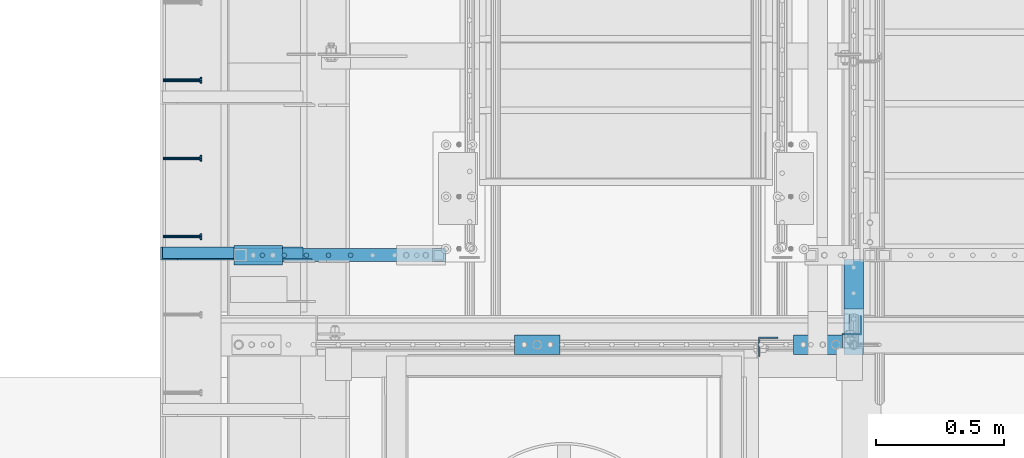
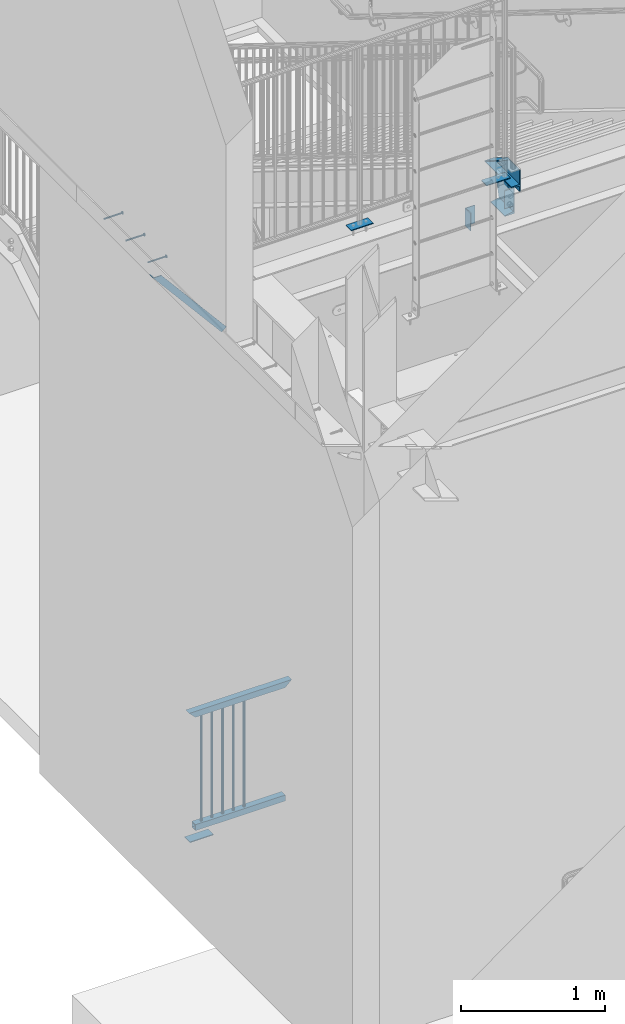
# One storey, part 1257 of 1763: 16 beams, 2 members, 8 elements without a shape of their own.
"""IFC2X3 building model written with IfcOpenShell, lengths in millimetres."""

from ifc_helpers import new_model, si_unit, frame, origin_with_axes, place, context, subcontext, project, spatial, faceted_brep, material, type_object, element, aggregate, save


model = new_model("IFC2X3")

# Units and contexts
model_context = context("Model", 3, precision=1e-05, world=origin_with_axes())
body_context = subcontext(model_context, "Body", "Model", "MODEL_VIEW")
ifc_project = project(units=[si_unit("LENGTHUNIT", "METRE", prefix="MILLI"), si_unit("AREAUNIT", "SQUARE_METRE"), si_unit("VOLUMEUNIT", "CUBIC_METRE"), si_unit("MASSUNIT", "GRAM", prefix="KILO"), si_unit("TIMEUNIT", "SECOND"), si_unit("PLANEANGLEUNIT", "RADIAN"), si_unit("SOLIDANGLEUNIT", "STERADIAN"), si_unit("THERMODYNAMICTEMPERATUREUNIT", "DEGREE_CELSIUS"), si_unit("LUMINOUSINTENSITYUNIT", "LUMEN")], contexts=[model_context])

# Site, building, storey
site_placement = place(None, origin_with_axes())
site = spatial("IfcSite", under=ifc_project, at=site_placement, CompositionType="ELEMENT")
building_placement = place(site_placement, origin_with_axes())
building = spatial("IfcBuilding", under=site, at=building_placement, Name="Undefined", CompositionType="ELEMENT")
storey_placement = place(building_placement, origin_with_axes())
storey = spatial("IfcBuildingStorey", under=building, at=storey_placement, Name="Undefined", CompositionType="ELEMENT", Elevation=0.0)

# Assembly, beam
assembly_1_placement = place(storey_placement, origin_with_axes())
assembly_1 = element("IfcElementAssembly", 1, at=assembly_1_placement, inside=storey, Name="HEADED STUD ANCHOR", AssemblyPlace="NOTDEFINED", PredefinedType="RIGID_FRAME")
ifc_material_1 = material(Name="STEEL/A108")
beam_type_1 = type_object("IfcBeamType", PredefinedType="NOTDEFINED")
beam_1_placement = place(assembly_1_placement, frame((-87975.5122736983, 32096.0750061035, 5268.91250001202), z_axis=(0.0, 0.0, -1.0), x_axis=(1.0, 0.0, 0.0)))
beam_1 = element("IfcBeam", 2, at=beam_1_placement, type_object=beam_type_1, material=ifc_material_1, Name="HEADED STUD ANCHOR", context=body_context, shape_type="Brep", body=[
    faceted_brep([(0.0, -3.1800000667572, 5.5), (0.0, -5.5, 3.1800000667572), (141.732000000002, -5.5, 3.1800000667572), (141.732000000002, -3.1800000667572, 5.5), (0.0, -6.34999999999491, 1.45519152283669e-11), (141.732000000002, -6.34999990463257, 0.0), (0.0, -5.5, -3.1800000667572), (141.732000000002, -5.5, -3.1800000667572), (0.0, -3.1800000667572, -5.5), (141.732000000002, -3.1800000667572, -5.5), (0.0, 0.0, -6.34999990463257), (141.732000000002, 0.0, -6.34999990463257), (0.0, 3.1800000667572, -5.5), (141.732000000002, 3.1800000667572, -5.5), (0.0, 5.5, -3.1800000667572), (141.732000000002, 5.5, -3.1800000667572), (0.0, 6.34999999999491, -2.91038304567337e-11), (141.732000000002, 6.34999990463257, 0.0), (0.0, 5.5, 3.1800000667572), (141.732000000002, 5.5, 3.1800000667572), (0.0, 3.1800000667572, 5.5), (141.732000000002, 3.1800000667572, 5.5), (0.0, 0.0, 6.34999990463257), (141.732000000002, 0.0, 6.34999990463257), (144.780000000001, -10.9899997711182, 6.34999990463257), (144.780000000001, -6.34000015258789, 10.9899997711182), (144.780000000001, -12.6999998092651, 0.0), (144.780000000001, -10.9899997711182, -6.34999990463257), (144.780000000001, -6.34000015258789, -10.9899997711182), (144.780000000001, 0.0, -12.6899995803833), (144.780000000001, 6.34000015258789, -10.9899997711182), (144.780000000001, 10.9899997711182, -6.34999990463257), (144.780000000001, 12.6999998092651, 0.0), (144.780000000001, 10.9899997711182, 6.34999990463257), (144.780000000001, 6.34000015258789, 10.9899997711182), (144.780000000001, 0.0, 12.6899995803833), (152.400000000001, -10.9899997711182, 6.34999990463257), (152.400000000001, -6.34000015258789, 10.9899997711182), (152.400000000001, -12.6999998092651, 0.0), (152.400000000001, -10.9899997711182, -6.34999990463257), (152.400000000001, -6.34000015258789, -10.9899997711182), (152.400000000001, 0.0, -12.6899995803833), (152.400000000001, 6.34000015258789, -10.9899997711182), (152.400000000001, 10.9899997711182, -6.34999990463257), (152.400000000001, 12.6999998092651, 0.0), (152.400000000001, 10.9899997711182, 6.34999990463257), (152.400000000001, 6.34000015258789, 10.9899997711182), (152.400000000001, 0.0, 12.6899995803833)], [[[0, 1, 2, 3]], [[1, 4, 5, 2]], [[4, 6, 7, 5]], [[6, 8, 9, 7]], [[8, 10, 11, 9]], [[10, 12, 13, 11]], [[12, 14, 15, 13]], [[14, 16, 17, 15]], [[16, 18, 19, 17]], [[18, 20, 21, 19]], [[20, 22, 23, 21]], [[22, 0, 3, 23]], [[22, 20, 18, 16, 14, 12, 10, 8, 6, 4, 1, 0]], [[3, 2, 24, 25]], [[2, 5, 26, 24]], [[5, 7, 27, 26]], [[7, 9, 28, 27]], [[9, 11, 29, 28]], [[11, 13, 30, 29]], [[13, 15, 31, 30]], [[15, 17, 32, 31]], [[17, 19, 33, 32]], [[19, 21, 34, 33]], [[21, 23, 35, 34]], [[23, 3, 25, 35]], [[25, 24, 36, 37]], [[24, 26, 38, 36]], [[26, 27, 39, 38]], [[27, 28, 40, 39]], [[28, 29, 41, 40]], [[29, 30, 42, 41]], [[30, 31, 43, 42]], [[31, 32, 44, 43]], [[32, 33, 45, 44]], [[33, 34, 46, 45]], [[34, 35, 47, 46]], [[35, 25, 37, 47]], [[38, 39, 40, 41, 42, 43, 44, 45, 46, 47, 37, 36]]]),
])
aggregate(assembly_1, [beam_1])

assembly_2_placement = place(storey_placement, origin_with_axes())
assembly_2 = element("IfcElementAssembly", 3, at=assembly_2_placement, inside=storey, Name="HEADED STUD ANCHOR", AssemblyPlace="NOTDEFINED", PredefinedType="RIGID_FRAME")
beam_2_placement = place(assembly_2_placement, frame((-87975.5122736983, 32400.8750061035, 5268.91250001202), z_axis=(0.0, 0.0, -1.0), x_axis=(1.0, 0.0, 0.0)))
beam_2 = element("IfcBeam", 4, at=beam_2_placement, type_object=beam_type_1, material=ifc_material_1, Name="HEADED STUD ANCHOR", context=body_context, shape_type="Brep", body=[
    faceted_brep([(0.0, -3.1800000667572, 5.5), (0.0, -5.5, 3.1800000667572), (141.732000000002, -5.5, 3.1800000667572), (141.732000000002, -3.1800000667572, 5.5), (0.0, -6.34999999999491, 1.45519152283669e-11), (141.732000000002, -6.34999990463257, 0.0), (0.0, -5.5, -3.1800000667572), (141.732000000002, -5.5, -3.1800000667572), (0.0, -3.1800000667572, -5.5), (141.732000000002, -3.1800000667572, -5.5), (0.0, 0.0, -6.34999990463257), (141.732000000002, 0.0, -6.34999990463257), (0.0, 3.1800000667572, -5.5), (141.732000000002, 3.1800000667572, -5.5), (0.0, 5.5, -3.1800000667572), (141.732000000002, 5.5, -3.1800000667572), (0.0, 6.34999999999491, -2.91038304567337e-11), (141.732000000002, 6.34999990463257, 0.0), (0.0, 5.5, 3.1800000667572), (141.732000000002, 5.5, 3.1800000667572), (0.0, 3.1800000667572, 5.5), (141.732000000002, 3.1800000667572, 5.5), (0.0, 0.0, 6.34999990463257), (141.732000000002, 0.0, 6.34999990463257), (144.780000000001, -10.9899997711182, 6.34999990463257), (144.780000000001, -6.34000015258789, 10.9899997711182), (144.780000000001, -12.6999998092651, 0.0), (144.780000000001, -10.9899997711182, -6.34999990463257), (144.780000000001, -6.34000015258789, -10.9899997711182), (144.780000000001, 0.0, -12.6899995803833), (144.780000000001, 6.34000015258789, -10.9899997711182), (144.780000000001, 10.9899997711182, -6.34999990463257), (144.780000000001, 12.6999998092651, 0.0), (144.780000000001, 10.9899997711182, 6.34999990463257), (144.780000000001, 6.34000015258789, 10.9899997711182), (144.780000000001, 0.0, 12.6899995803833), (152.400000000001, -10.9899997711182, 6.34999990463257), (152.400000000001, -6.34000015258789, 10.9899997711182), (152.400000000001, -12.6999998092651, 0.0), (152.400000000001, -10.9899997711182, -6.34999990463257), (152.400000000001, -6.34000015258789, -10.9899997711182), (152.400000000001, 0.0, -12.6899995803833), (152.400000000001, 6.34000015258789, -10.9899997711182), (152.400000000001, 10.9899997711182, -6.34999990463257), (152.400000000001, 12.6999998092651, 0.0), (152.400000000001, 10.9899997711182, 6.34999990463257), (152.400000000001, 6.34000015258789, 10.9899997711182), (152.400000000001, 0.0, 12.6899995803833)], [[[0, 1, 2, 3]], [[1, 4, 5, 2]], [[4, 6, 7, 5]], [[6, 8, 9, 7]], [[8, 10, 11, 9]], [[10, 12, 13, 11]], [[12, 14, 15, 13]], [[14, 16, 17, 15]], [[16, 18, 19, 17]], [[18, 20, 21, 19]], [[20, 22, 23, 21]], [[22, 0, 3, 23]], [[22, 20, 18, 16, 14, 12, 10, 8, 6, 4, 1, 0]], [[3, 2, 24, 25]], [[2, 5, 26, 24]], [[5, 7, 27, 26]], [[7, 9, 28, 27]], [[9, 11, 29, 28]], [[11, 13, 30, 29]], [[13, 15, 31, 30]], [[15, 17, 32, 31]], [[17, 19, 33, 32]], [[19, 21, 34, 33]], [[21, 23, 35, 34]], [[23, 3, 25, 35]], [[25, 24, 36, 37]], [[24, 26, 38, 36]], [[26, 27, 39, 38]], [[27, 28, 40, 39]], [[28, 29, 41, 40]], [[29, 30, 42, 41]], [[30, 31, 43, 42]], [[31, 32, 44, 43]], [[32, 33, 45, 44]], [[33, 34, 46, 45]], [[34, 35, 47, 46]], [[35, 25, 37, 47]], [[38, 39, 40, 41, 42, 43, 44, 45, 46, 47, 37, 36]]]),
])
aggregate(assembly_2, [beam_2])

assembly_3_placement = place(storey_placement, origin_with_axes())
assembly_3 = element("IfcElementAssembly", 5, at=assembly_3_placement, inside=storey, Name="HEADED STUD ANCHOR", AssemblyPlace="NOTDEFINED", PredefinedType="RIGID_FRAME")
beam_3_placement = place(assembly_3_placement, frame((-87975.5122736983, 32705.6750061035, 5268.91250001202), z_axis=(0.0, 0.0, -1.0), x_axis=(1.0, 0.0, 0.0)))
beam_3 = element("IfcBeam", 6, at=beam_3_placement, type_object=beam_type_1, material=ifc_material_1, Name="HEADED STUD ANCHOR", context=body_context, shape_type="Brep", body=[
    faceted_brep([(0.0, -3.1800000667572, 5.5), (0.0, -5.5, 3.1800000667572), (141.732000000002, -5.5, 3.1800000667572), (141.732000000002, -3.1800000667572, 5.5), (0.0, -6.34999999999491, 1.45519152283669e-11), (141.732000000002, -6.34999990463257, 0.0), (0.0, -5.5, -3.1800000667572), (141.732000000002, -5.5, -3.1800000667572), (0.0, -3.1800000667572, -5.5), (141.732000000002, -3.1800000667572, -5.5), (0.0, 0.0, -6.34999990463257), (141.732000000002, 0.0, -6.34999990463257), (0.0, 3.1800000667572, -5.5), (141.732000000002, 3.1800000667572, -5.5), (0.0, 5.5, -3.1800000667572), (141.732000000002, 5.5, -3.1800000667572), (0.0, 6.34999999999491, -2.91038304567337e-11), (141.732000000002, 6.34999990463257, 0.0), (0.0, 5.5, 3.1800000667572), (141.732000000002, 5.5, 3.1800000667572), (0.0, 3.1800000667572, 5.5), (141.732000000002, 3.1800000667572, 5.5), (0.0, 0.0, 6.34999990463257), (141.732000000002, 0.0, 6.34999990463257), (144.780000000001, -10.9899997711182, 6.34999990463257), (144.780000000001, -6.34000015258789, 10.9899997711182), (144.780000000001, -12.6999998092651, 0.0), (144.780000000001, -10.9899997711182, -6.34999990463257), (144.780000000001, -6.34000015258789, -10.9899997711182), (144.780000000001, 0.0, -12.6899995803833), (144.780000000001, 6.34000015258789, -10.9899997711182), (144.780000000001, 10.9899997711182, -6.34999990463257), (144.780000000001, 12.6999998092651, 0.0), (144.780000000001, 10.9899997711182, 6.34999990463257), (144.780000000001, 6.34000015258789, 10.9899997711182), (144.780000000001, 0.0, 12.6899995803833), (152.400000000001, -10.9899997711182, 6.34999990463257), (152.400000000001, -6.34000015258789, 10.9899997711182), (152.400000000001, -12.6999998092651, 0.0), (152.400000000001, -10.9899997711182, -6.34999990463257), (152.400000000001, -6.34000015258789, -10.9899997711182), (152.400000000001, 0.0, -12.6899995803833), (152.400000000001, 6.34000015258789, -10.9899997711182), (152.400000000001, 10.9899997711182, -6.34999990463257), (152.400000000001, 12.6999998092651, 0.0), (152.400000000001, 10.9899997711182, 6.34999990463257), (152.400000000001, 6.34000015258789, 10.9899997711182), (152.400000000001, 0.0, 12.6899995803833)], [[[0, 1, 2, 3]], [[1, 4, 5, 2]], [[4, 6, 7, 5]], [[6, 8, 9, 7]], [[8, 10, 11, 9]], [[10, 12, 13, 11]], [[12, 14, 15, 13]], [[14, 16, 17, 15]], [[16, 18, 19, 17]], [[18, 20, 21, 19]], [[20, 22, 23, 21]], [[22, 0, 3, 23]], [[22, 20, 18, 16, 14, 12, 10, 8, 6, 4, 1, 0]], [[3, 2, 24, 25]], [[2, 5, 26, 24]], [[5, 7, 27, 26]], [[7, 9, 28, 27]], [[9, 11, 29, 28]], [[11, 13, 30, 29]], [[13, 15, 31, 30]], [[15, 17, 32, 31]], [[17, 19, 33, 32]], [[19, 21, 34, 33]], [[21, 23, 35, 34]], [[23, 3, 25, 35]], [[25, 24, 36, 37]], [[24, 26, 38, 36]], [[26, 27, 39, 38]], [[27, 28, 40, 39]], [[28, 29, 41, 40]], [[29, 30, 42, 41]], [[30, 31, 43, 42]], [[31, 32, 44, 43]], [[32, 33, 45, 44]], [[33, 34, 46, 45]], [[34, 35, 47, 46]], [[35, 25, 37, 47]], [[38, 39, 40, 41, 42, 43, 44, 45, 46, 47, 37, 36]]]),
])
aggregate(assembly_3, [beam_3])

assembly_4_placement = place(storey_placement, origin_with_axes())
assembly_4 = element("IfcElementAssembly", 7, at=assembly_4_placement, inside=storey, Name="STRINGER", AssemblyPlace="NOTDEFINED", PredefinedType="RIGID_FRAME")
ifc_material_2 = material(Name="STEEL/A36")
beam_type_2 = type_object("IfcBeamType", Name="C12X20.7", PredefinedType="NOTDEFINED")
beam_4_placement = place(assembly_4_placement, frame((-85279.8721012589, 32158.1867648324, 5105.40000004609), z_axis=(0.0, 0.0, 1.0), x_axis=(0.0, -1.0, 0.0)))
beam_4 = element("IfcBeam", 8, at=beam_4_placement, type_object=beam_type_2, material=ifc_material_2, Name="STRINGER", ObjectType="C12X20.7", context=body_context, shape_type="Brep", body=[
    faceted_brep([(363.736764736321, -38.1000000021013, 152.399999999982), (363.736764736321, -38.1000000020867, 146.047459999982), (363.736764714082, -15.9401715282875, 142.355632576261), (363.736764714082, -15.9401715182757, 152.399999999992), (398.661763951142, -15.9401714934793, 142.35563257044), (398.661763951142, -15.9401714834821, 152.399999999992), (398.661763973381, -38.0999996986793, 152.399999999982), (398.661763973381, -38.1000000022323, 146.047459999982), (522.486764629593, 30.1624999973137, 134.674927500014), (156.09094766156, 30.1624999988271, 134.674927500014), (232.902128590707, 30.1624999995984, -134.674927499987), (433.586766194388, 30.1624999987835, -134.674927499987), (433.586766193777, 30.1624999978667, 88.8999877296428), (522.486764629593, 30.1624999975029, 88.8999877302549), (236.145262600185, -38.1000000003551, -146.047460000017), (433.586766262648, -38.10000000117, -146.047460000017), (237.956832535128, -38.1000000003405, -152.400000000017), (237.956832436834, 38.0999999996566, -152.399999999983), (433.58676618645, 38.0999999988562, -152.399999999983), (433.586766262648, -38.1000000011409, -152.400000000017), (433.58676618581, 38.0999999978667, 88.8999877216766), (152.847813828193, -38.1000000012136, 146.047459999982), (151.03624389325, -38.1000000012427, 152.399999999982), (151.036243794955, 38.0999999987544, 152.400000000016), (522.486764629597, 38.099999997241, 152.400000000016), (522.486764629597, 38.0999999975029, 88.8999877223168), (522.486764629557, -38.1000000027561, 152.399999999982), (522.486764629557, -38.100000002727, 146.047459999982)], [[[0, 1, 2, 3]], [[3, 2, 4, 5]], [[6, 5, 4, 7]], [[8, 9, 10, 11, 12, 13]], [[10, 14, 15, 11]], [[16, 17, 18, 19]], [[11, 15, 19, 18, 20, 12]], [[14, 16, 19, 15]], [[10, 9, 21, 22, 23, 17, 16, 14]], [[18, 17, 23, 24, 25, 20]], [[13, 12, 20, 25]], [[24, 26, 27, 8, 13, 25]], [[27, 26, 6, 7]], [[2, 1, 21, 9, 8, 27, 7, 4]], [[22, 21, 1, 0]], [[26, 24, 23, 22, 0, 3, 5, 6]]]),
])

# Assembly, member
assembly_5_placement = place(storey_placement, origin_with_axes())
assembly_5 = element("IfcElementAssembly", 9, at=assembly_5_placement, inside=storey, Name="BEAM", AssemblyPlace="NOTDEFINED", PredefinedType="RIGID_FRAME")
member_type_1 = type_object("IfcMemberType", Name="L2X2X1/4", PredefinedType="NOTDEFINED")
member_1_placement = place(assembly_5_placement, frame((-87414.1929584935, 32029.4, 4557.35349338836), z_axis=(0.764183480307171, 0.0, 0.644998921259268), x_axis=(-0.644998921259266, 0.0, 0.764183480307173)))
member_1 = element("IfcMember", 10, at=member_1_placement, type_object=member_type_1, material=ifc_material_2, Name="ANGLE", ObjectType="L2X2X1/4", context=body_context, shape_type="Brep", body=[
    faceted_brep([(-1.45519152283669e-11, 25.4000000000015, -25.3999999999869), (1.45519152283669e-11, 25.4000000000015, 25.3999999999796), (812.060911532491, 25.4000000000015, 25.400000001966), (854.937976763787, 25.4000000000015, -25.3999999979424), (1.45519152283669e-11, 19.0499999999993, 25.3999999999796), (812.060911532491, 19.0500000000029, 25.400000001966), (-7.27595761418343e-12, 19.0499999999993, -19.0499999999956), (849.578343609872, 19.0500000000029, -19.0499999979511), (-7.27595761418343e-12, -25.4000000000015, -19.0499999999956), (849.578343609872, -25.4000000000015, -19.0499999979511), (-1.45519152283669e-11, -25.4000000000015, -25.3999999999869), (854.937976763787, -25.4000000000015, -25.3999999979424)], [[[0, 1, 2, 3]], [[1, 4, 5, 2]], [[4, 6, 7, 5]], [[6, 8, 9, 7]], [[8, 10, 11, 9]], [[10, 0, 3, 11]], [[5, 7, 9, 11, 3, 2]], [[10, 8, 6, 4, 1, 0]]]),
])
aggregate(assembly_5, [member_1])

# Assembly, beam
assembly_6_placement = place(storey_placement, origin_with_axes())
assembly_6 = element("IfcElementAssembly", 11, at=assembly_6_placement, inside=storey, Name="GUARDRAIL", AssemblyPlace="NOTDEFINED", PredefinedType="RIGID_FRAME")
beam_type_3 = type_object("IfcBeamType", PredefinedType="NOTDEFINED")
beam_5_placement = place(assembly_6_placement, frame((-87604.0372736983, 32061.1500064728, 307.975030132566), z_axis=(1.0, 0.0, 0.0), x_axis=(0.0, -1.0, 0.0)))
beam_5 = element("IfcBeam", 12, at=beam_5_placement, type_object=beam_type_3, material=ifc_material_2, context=body_context, shape_type="Brep", body=[
    faceted_brep([(0.0, 3.17500000000001, -95.25), (0.0, 3.17499999999927, 95.25), (76.1999968561649, 3.17499999984284, 95.25), (76.1999999999971, 3.17500000000001, -95.25), (0.0, -3.17499999999927, 95.25), (76.1999970403122, -3.17500000015571, 95.25), (0.0, -3.17500000000001, -95.25), (76.1999999999971, -3.17500000000001, -95.25)], [[[0, 1, 2, 3]], [[1, 4, 5, 2]], [[4, 6, 7, 5]], [[6, 0, 3, 7]], [[5, 7, 3, 2]], [[6, 4, 1, 0]]]),
])

# Assembly, beams
assembly_7_placement = place(storey_placement, origin_with_axes())
assembly_7 = element("IfcElementAssembly", 13, at=assembly_7_placement, inside=storey, Name="RAIL", AssemblyPlace="NOTDEFINED", PredefinedType="RIGID_FRAME")
beam_6_placement = place(assembly_7_placement, frame((-86514.9796871236, 31635.7000005484, 5337.175), z_axis=(-1.0, 0.0, 0.0), x_axis=(0.0, 1.0, 0.0)))
beam_6 = element("IfcBeam", 14, at=beam_6_placement, type_object=beam_type_3, material=ifc_material_2, context=body_context, shape_type="Brep", body=[
    faceted_brep([(0.0, 3.17500000000018, -88.8999999999942), (0.0, 3.17499999999927, 88.9000015258789), (76.1999999999971, 3.17500000000018, 88.8999999999942), (76.1999999999971, 3.17500000000018, -88.8999999999942), (0.0, -3.17499999999927, 88.9000015258789), (76.1999999999971, -3.17500000000018, 88.8999999999942), (0.0, -3.17500000000018, -88.8999999999942), (76.1999999999971, -3.17500000000018, -88.8999999999942)], [[[0, 1, 2, 3]], [[1, 4, 5, 2]], [[4, 6, 7, 5]], [[6, 0, 3, 7]], [[5, 7, 3, 2]], [[6, 4, 1, 0]]]),
])
beam_7_placement = place(assembly_7_placement, frame((-85419.5721005486, 31635.700001448, 5337.175), z_axis=(-1.0, 0.0, 0.0), x_axis=(0.0, 1.0, 0.0)))
beam_7 = element("IfcBeam", 15, at=beam_7_placement, type_object=beam_type_3, material=ifc_material_2, context=body_context, shape_type="Brep", body=[
    faceted_brep([(0.0, 3.17500000000001, -95.25), (0.0, 3.17499999999927, 95.25), (76.1999968561649, 3.17499999984284, 95.25), (76.1999999999971, 3.17500000000001, -95.25), (0.0, -3.17499999999927, 95.25), (76.1999970403122, -3.17500000015571, 95.25), (0.0, -3.17500000000001, -95.25), (76.1999999999971, -3.17500000000001, -95.25)], [[[0, 1, 2, 3]], [[1, 4, 5, 2]], [[4, 6, 7, 5]], [[6, 0, 3, 7]], [[5, 7, 3, 2]], [[6, 4, 1, 0]]]),
])
aggregate(assembly_7, [beam_6, beam_7])

# Beam
beam_type_4 = type_object("IfcBeamType", PredefinedType="NOTDEFINED")
beam_8_placement = place(assembly_6_placement, frame((-87243.4983848231, 32023.0500064728, 1346.20003013257), z_axis=(1.0, 0.0, 0.0), x_axis=(0.0, 0.0, -1.0)))
beam_8 = element("IfcBeam", 16, at=beam_8_placement, type_object=beam_type_4, material=ifc_material_2, Name="PICKET", context=body_context, shape_type="Brep", body=[
    faceted_brep([(0.0, -9.52500000000146, 0.0), (0.0, -6.73519209080041, -6.73519209079677), (913.809358181841, -6.73519209080041, -6.73519209079677), (913.809358181841, -9.52500000000146, 0.0), (0.0, 0.0, -9.52499999999418), (913.809358181841, 0.0, -9.52499999999418), (0.0, 6.73519209080041, -6.73519209079677), (913.809358181841, 6.73519209080041, -6.73519209079677), (0.0, 9.52500000000146, 0.0), (913.809358181841, 9.52500000000146, 0.0), (0.0, 6.73519209080041, 6.73519209079677), (913.809358181841, 6.73519209080041, 6.73519209079677), (0.0, 0.0, 9.52499999999418), (913.809358181841, 0.0, 9.52499999999418), (0.0, -6.73519209080041, 6.73519209079677), (913.809358181841, -6.73519209080041, 6.73519209079677)], [[[0, 1, 2, 3]], [[1, 4, 5, 2]], [[4, 6, 7, 5]], [[6, 8, 9, 7]], [[8, 10, 11, 9]], [[10, 12, 13, 11]], [[12, 14, 15, 13]], [[14, 0, 3, 15]], [[5, 7, 9, 11, 13, 15, 3, 2]], [[14, 12, 10, 8, 6, 4, 1, 0]]]),
])

beam_9_placement = place(assembly_6_placement, frame((-87329.5761625981, 32023.0500064728, 1346.20003013257), z_axis=(1.0, 0.0, 0.0), x_axis=(0.0, 0.0, -1.0)))
beam_9 = element("IfcBeam", 17, at=beam_9_placement, type_object=beam_type_4, material=ifc_material_2, Name="PICKET", context=body_context, shape_type="Brep", body=[
    faceted_brep([(0.0, -9.52500000000146, 0.0), (0.0, -6.73519209080041, -6.73519209079677), (913.809358181841, -6.73519209080041, -6.73519209079677), (913.809358181841, -9.52500000000146, 0.0), (0.0, 0.0, -9.52499999999418), (913.809358181841, 0.0, -9.52499999999418), (0.0, 6.73519209080041, -6.73519209079677), (913.809358181841, 6.73519209080041, -6.73519209079677), (0.0, 9.52500000000146, 0.0), (913.809358181841, 9.52500000000146, 0.0), (0.0, 6.73519209080041, 6.73519209079677), (913.809358181841, 6.73519209080041, 6.73519209079677), (0.0, 0.0, 9.52499999999418), (913.809358181841, 0.0, 9.52499999999418), (0.0, -6.73519209080041, 6.73519209079677), (913.809358181841, -6.73519209080041, 6.73519209079677)], [[[0, 1, 2, 3]], [[1, 4, 5, 2]], [[4, 6, 7, 5]], [[6, 8, 9, 7]], [[8, 10, 11, 9]], [[10, 12, 13, 11]], [[12, 14, 15, 13]], [[14, 0, 3, 15]], [[5, 7, 9, 11, 13, 15, 3, 2]], [[14, 12, 10, 8, 6, 4, 1, 0]]]),
])

beam_10_placement = place(assembly_6_placement, frame((-87415.6539403732, 32023.0500064728, 1346.20003013257), z_axis=(1.0, 0.0, 0.0), x_axis=(0.0, 0.0, -1.0)))
beam_10 = element("IfcBeam", 18, at=beam_10_placement, type_object=beam_type_4, material=ifc_material_2, Name="PICKET", context=body_context, shape_type="Brep", body=[
    faceted_brep([(0.0, -9.52500000000146, 0.0), (0.0, -6.73519209080041, -6.73519209079677), (913.809358181841, -6.73519209080041, -6.73519209079677), (913.809358181841, -9.52500000000146, 0.0), (0.0, 0.0, -9.52499999999418), (913.809358181841, 0.0, -9.52499999999418), (0.0, 6.73519209080041, -6.73519209079677), (913.809358181841, 6.73519209080041, -6.73519209079677), (0.0, 9.52500000000146, 0.0), (913.809358181841, 9.52500000000146, 0.0), (0.0, 6.73519209080041, 6.73519209079677), (913.809358181841, 6.73519209080041, 6.73519209079677), (0.0, 0.0, 9.52499999999418), (913.809358181841, 0.0, 9.52499999999418), (0.0, -6.73519209080041, 6.73519209079677), (913.809358181841, -6.73519209080041, 6.73519209079677)], [[[0, 1, 2, 3]], [[1, 4, 5, 2]], [[4, 6, 7, 5]], [[6, 8, 9, 7]], [[8, 10, 11, 9]], [[10, 12, 13, 11]], [[12, 14, 15, 13]], [[14, 0, 3, 15]], [[5, 7, 9, 11, 13, 15, 3, 2]], [[14, 12, 10, 8, 6, 4, 1, 0]]]),
])

beam_11_placement = place(assembly_6_placement, frame((-87501.7317181483, 32023.0500064728, 1346.20003013257), z_axis=(1.0, 0.0, 0.0), x_axis=(0.0, 0.0, -1.0)))
beam_11 = element("IfcBeam", 19, at=beam_11_placement, type_object=beam_type_4, material=ifc_material_2, Name="PICKET", context=body_context, shape_type="Brep", body=[
    faceted_brep([(0.0, -9.52500000000146, 0.0), (0.0, -6.73519209080041, -6.73519209079677), (913.809358181841, -6.73519209080041, -6.73519209079677), (913.809358181841, -9.52500000000146, 0.0), (0.0, 0.0, -9.52499999999418), (913.809358181841, 0.0, -9.52499999999418), (0.0, 6.73519209080041, -6.73519209079677), (913.809358181841, 6.73519209080041, -6.73519209079677), (0.0, 9.52500000000146, 0.0), (913.809358181841, 9.52500000000146, 0.0), (0.0, 6.73519209080041, 6.73519209079677), (913.809358181841, 6.73519209080041, 6.73519209079677), (0.0, 0.0, 9.52499999999418), (913.809358181841, 0.0, 9.52499999999418), (0.0, -6.73519209080041, 6.73519209079677), (913.809358181841, -6.73519209080041, 6.73519209079677)], [[[0, 1, 2, 3]], [[1, 4, 5, 2]], [[4, 6, 7, 5]], [[6, 8, 9, 7]], [[8, 10, 11, 9]], [[10, 12, 13, 11]], [[12, 14, 15, 13]], [[14, 0, 3, 15]], [[5, 7, 9, 11, 13, 15, 3, 2]], [[14, 12, 10, 8, 6, 4, 1, 0]]]),
])

beam_12_placement = place(assembly_6_placement, frame((-87587.8094959233, 32023.0500064728, 1346.20003013257), z_axis=(1.0, 0.0, 0.0), x_axis=(0.0, 0.0, -1.0)))
beam_12 = element("IfcBeam", 20, at=beam_12_placement, type_object=beam_type_4, material=ifc_material_2, Name="PICKET", context=body_context, shape_type="Brep", body=[
    faceted_brep([(0.0, -9.52500000000146, 0.0), (0.0, -6.73519209080041, -6.73519209079677), (913.809358181841, -6.73519209080041, -6.73519209079677), (913.809358181841, -9.52500000000146, 0.0), (0.0, 0.0, -9.52499999999418), (913.809358181841, 0.0, -9.52499999999418), (0.0, 6.73519209080041, -6.73519209079677), (913.809358181841, 6.73519209080041, -6.73519209079677), (0.0, 9.52500000000146, 0.0), (913.809358181841, 9.52500000000146, 0.0), (0.0, 6.73519209080041, 6.73519209079677), (913.809358181841, 6.73519209080041, 6.73519209079677), (0.0, 0.0, 9.52499999999418), (913.809358181841, 0.0, 9.52499999999418), (0.0, -6.73519209080041, 6.73519209079677), (913.809358181841, -6.73519209080041, 6.73519209079677)], [[[0, 1, 2, 3]], [[1, 4, 5, 2]], [[4, 6, 7, 5]], [[6, 8, 9, 7]], [[8, 10, 11, 9]], [[10, 12, 13, 11]], [[12, 14, 15, 13]], [[14, 0, 3, 15]], [[5, 7, 9, 11, 13, 15, 3, 2]], [[14, 12, 10, 8, 6, 4, 1, 0]]]),
])

ifc_material_3 = material()
beam_type_5 = type_object("IfcBeamType", Name="HSS2X2X1/4", PredefinedType="NOTDEFINED")
beam_13_placement = place(assembly_6_placement, frame((-87673.8872736983, 32023.0500064728, 407.046967539092), z_axis=(-3.04189999878872e-05, 0.0, 0.999999999537342), x_axis=(0.999999999537342, 0.0, 3.04189999859577e-05)))
beam_13 = element("IfcBeam", 21, at=beam_13_placement, type_object=beam_type_5, material=ifc_material_3, Name="GUARDRAIL", ObjectType="HSS2X2X1/4", context=body_context, shape_type="Brep", body=[
    faceted_brep([(25.3994205297204, 19.0499999999993, -19.0500000000003), (25.3994205297204, -19.0499999999993, -19.0500000000003), (749.29942083577, -19.0499999999993, -19.0500000000018), (749.29942083577, 19.0499999999993, -19.0500000000018), (25.4005794934783, -19.0499999999993, 19.0500000000001), (749.300579799528, -19.0499999999993, 19.0499999999986), (25.4005794934783, 19.0499999999993, 19.0500000000001), (749.300579799528, 19.0499999999993, 19.0499999999986), (25.3992273690819, 25.4000000000015, -25.4000000000003), (25.4007726541022, 25.4000000000015, 25.4000000000001), (749.300772960152, 25.4000000000015, 25.3999999999987), (749.299227675132, 25.4000000000015, -25.4000000000019), (25.4007726541022, -25.4000000000015, 25.4000000000001), (749.300772960152, -25.4000000000015, 25.3999999999987), (25.3992273690819, -25.4000000000015, -25.4000000000003), (749.299227675132, -25.4000000000015, -25.4000000000019)], [[[0, 1, 2, 3]], [[1, 4, 5, 2]], [[4, 6, 7, 5]], [[6, 0, 3, 7]], [[8, 9, 10, 11]], [[9, 12, 13, 10]], [[12, 14, 15, 13]], [[14, 8, 11, 15]], [[13, 15, 11, 10], [5, 7, 3, 2]], [[14, 12, 9, 8], [6, 4, 1, 0]]]),
])

beam_14_placement = place(assembly_6_placement, frame((-87673.8872736983, 32023.0500064728, 1371.60003013257), z_axis=(0.0, 0.0, 1.0), x_axis=(1.0, 0.0, 0.0)))
beam_14 = element("IfcBeam", 22, at=beam_14_placement, type_object=beam_type_5, material=ifc_material_3, Name="GUARDRAIL", ObjectType="HSS2X2X1/4", context=body_context, shape_type="Brep", body=[
    faceted_brep([(19.0500000000052, 19.0499999999993, -19.0500000000029), (19.0500000000052, -19.0499999999993, -19.0500000000029), (755.649999975474, -19.0499999999993, -19.05), (755.649999975474, 19.0499999999993, -19.05), (-19.0499999999993, -19.0499999999993, 19.0500000000029), (793.749999975465, -19.0499999999993, 19.05), (-19.0499999999993, 19.0499999999993, 19.0500000000029), (793.749999975465, 19.0499999999993, 19.05), (25.400000000006, 25.4000000000015, -25.3999999999942), (-25.4000000000001, 25.4000000000015, 25.3999999999942), (800.099999975457, 25.4000000000015, 25.4000000000001), (749.299999975468, 25.4000000000015, -25.4000000000001), (-25.4000000000001, -25.4000000000015, 25.3999999999942), (800.099999975457, -25.4000000000015, 25.4000000000001), (25.400000000006, -25.4000000000015, -25.3999999999942), (749.299999975468, -25.4000000000015, -25.4000000000001)], [[[0, 1, 2, 3]], [[1, 4, 5, 2]], [[4, 6, 7, 5]], [[6, 0, 3, 7]], [[8, 9, 10, 11]], [[9, 12, 13, 10]], [[12, 14, 15, 13]], [[14, 8, 11, 15]], [[13, 15, 11, 10], [5, 7, 3, 2]], [[14, 12, 9, 8], [6, 4, 1, 0]]]),
])

aggregate(assembly_6, [beam_5, beam_8, beam_9, beam_10, beam_11, beam_12, beam_13, beam_14])

# Assembly, beam
assembly_8_placement = place(storey_placement, origin_with_axes())
assembly_8 = element("IfcElementAssembly", 23, at=assembly_8_placement, inside=storey, Name="CHANNEL", AssemblyPlace="NOTDEFINED", PredefinedType="RIGID_FRAME")
beam_type_6 = type_object("IfcBeamType", Name="L3X3X1/4", PredefinedType="NOTDEFINED")
beam_15_placement = place(assembly_8_placement, frame((-85613.2470001979, 31665.8625001342, 5156.20000006338), z_axis=(1.0, 0.0, 0.0), x_axis=(0.0, 0.0, -1.0)))
beam_15 = element("IfcBeam", 24, at=beam_15_placement, type_object=beam_type_6, material=ifc_material_2, Name="ANGLE", ObjectType="L3X3X1/4", context=body_context, shape_type="Brep", body=[
    faceted_brep([(0.0, 38.0999999999985, -38.1000000000004), (0.0, 38.0999999999985, 38.1000000000004), (152.400006103515, 38.0999999999985, 38.1000000000058), (152.400006103515, 38.0999999999985, -38.1000000000058), (0.0, 31.75, 38.1000000000058), (152.400006103515, 31.75, 38.1000000000058), (0.0, 31.75, -31.75), (152.400006103515, 31.75, -31.75), (0.0, -38.1000000000004, -31.75), (152.400006103515, -38.0999999999985, -31.75), (0.0, -38.0999999999985, -38.1000000000004), (152.400006103515, -38.0999999999985, -38.1000000000058)], [[[0, 1, 2, 3]], [[1, 4, 5, 2]], [[4, 6, 7, 5]], [[6, 8, 9, 7]], [[8, 10, 11, 9]], [[10, 0, 3, 11]], [[5, 7, 9, 11, 3, 2]], [[10, 8, 6, 4, 1, 0]]]),
])
aggregate(assembly_8, [beam_15])

# Beam
beam_16_placement = place(assembly_4_placement, frame((-85287.8096015502, 31749.9999993711, 5181.60000307164), z_axis=(-1.0, 0.0, 0.0), x_axis=(0.0, 0.0, -1.0)))
beam_16 = element("IfcBeam", 25, at=beam_16_placement, type_object=beam_type_6, material=ifc_material_2, Name="ANGLE", ObjectType="L3X3X1/4", context=body_context, shape_type="Brep", body=[
    faceted_brep([(0.0, 38.0999999999985, -38.1000000000004), (0.0, 38.0999999999985, 38.1000000000004), (152.400006103515, 38.0999999999985, 38.1000000000058), (152.400006103515, 38.0999999999985, -38.1000000000058), (0.0, 31.75, 38.1000000000058), (152.400006103515, 31.75, 38.1000000000058), (0.0, 31.75, -31.75), (152.400006103515, 31.75, -31.75), (0.0, -38.1000000000004, -31.75), (152.400006103515, -38.0999999999985, -31.75), (0.0, -38.0999999999985, -38.1000000000004), (152.400006103515, -38.0999999999985, -38.1000000000058)], [[[0, 1, 2, 3]], [[1, 4, 5, 2]], [[4, 6, 7, 5]], [[6, 8, 9, 7]], [[8, 10, 11, 9]], [[10, 0, 3, 11]], [[5, 7, 9, 11, 3, 2]], [[10, 8, 6, 4, 1, 0]]]),
])

# Member
member_type_2 = type_object("IfcMemberType", Name="C12X20.7", PredefinedType="NOTDEFINED")
member_2_placement = place(assembly_4_placement, frame((-85279.9372736932, 31926.7531822168, 5128.33174951326), z_axis=(0.0, 0.527541593960468, 0.849529202936338), x_axis=(0.0, -0.849529202936338, 0.527541593960467)))
member_2 = element("IfcMember", 26, at=member_2_placement, type_object=member_type_2, material=ifc_material_2, Name="STRINGER", ObjectType="C12X20.7", context=body_context, shape_type="Brep", body=[
    faceted_brep([(228.70234371992, 38.1000000000058, 152.400000000071), (228.70234371992, -38.1000000000058, 152.400000000071), (238.9321879196, -38.1000000000058, 146.047460000063), (257.246001863441, 30.1625000000058, 134.674927500051), (379.205956983718, 30.1625000000058, 58.9400992683077), (379.205956983718, 38.1000000000058, 58.9400992683077), (315.55806427557, 30.1625000000058, -43.555599467014), (315.55806427557, 38.1000000000058, -43.555599467014), (0.0, 38.1000000000004, 152.4), (0.0, -38.1000000000004, 152.4), (10.2298440420491, -38.1000000000058, 146.047460000089), (28.5436577407017, 30.1625000000058, 134.674927500084)], [[[0, 1, 2, 3, 4, 5]], [[5, 4, 6, 7]], [[0, 5, 7, 8]], [[1, 0, 8, 9]], [[2, 1, 9, 10]], [[3, 2, 10, 11]], [[4, 3, 11, 6]], [[10, 9, 8, 7, 6, 11]]]),
])

aggregate(assembly_4, [beam_16, member_2, beam_4])

save(model, "model.ifc")
